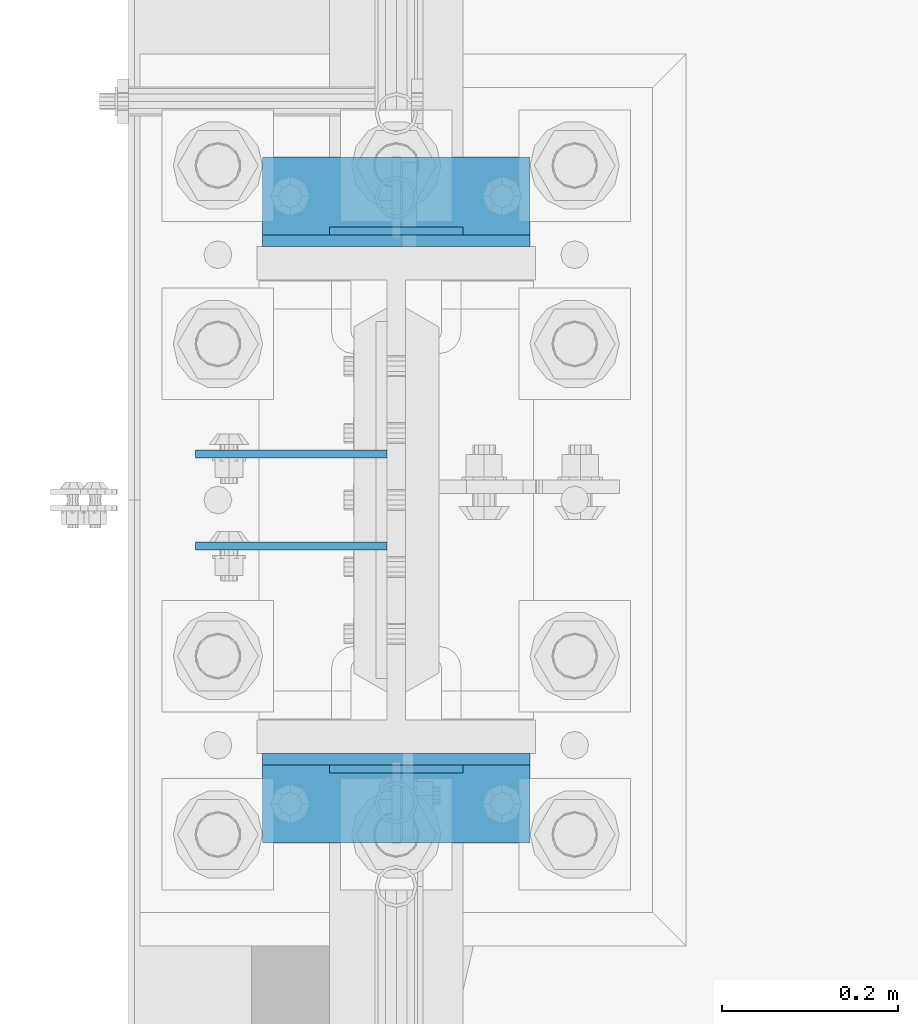
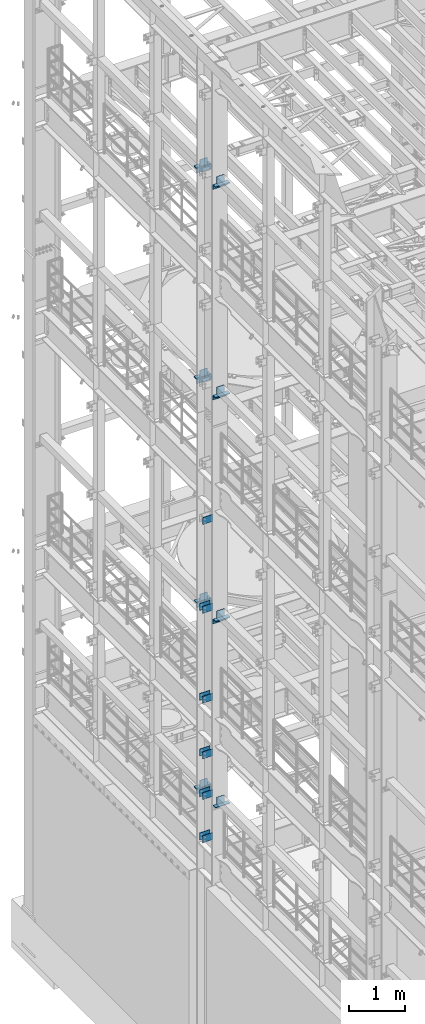
# One storey, part 1288 of 1876: 34 beams, 10 elements without a shape of their own.
"""IFC2X3 building model written with IfcOpenShell, lengths in millimetres."""

from ifc_helpers import new_model, si_unit, frame, origin_with_axes, place, context, subcontext, project, spatial, faceted_brep, material, type_object, element, aggregate, save


model = new_model("IFC2X3")

# Units and contexts
model_context = context("Model", 3, precision=1e-05, world=origin_with_axes())
body_context = subcontext(model_context, "Body", "Model", "MODEL_VIEW")
ifc_project = project(units=[si_unit("LENGTHUNIT", "METRE", prefix="MILLI"), si_unit("AREAUNIT", "SQUARE_METRE"), si_unit("VOLUMEUNIT", "CUBIC_METRE"), si_unit("MASSUNIT", "GRAM", prefix="KILO"), si_unit("TIMEUNIT", "SECOND"), si_unit("PLANEANGLEUNIT", "RADIAN"), si_unit("SOLIDANGLEUNIT", "STERADIAN"), si_unit("THERMODYNAMICTEMPERATUREUNIT", "DEGREE_CELSIUS"), si_unit("LUMINOUSINTENSITYUNIT", "LUMEN")], contexts=[model_context])

# Site, building, storey
site_placement = place(None, origin_with_axes())
site = spatial("IfcSite", under=ifc_project, at=site_placement, CompositionType="ELEMENT")
building_placement = place(site_placement, origin_with_axes())
building = spatial("IfcBuilding", under=site, at=building_placement, Name="Undefined", CompositionType="ELEMENT")
storey_placement = place(building_placement, origin_with_axes())
storey = spatial("IfcBuildingStorey", under=building, at=storey_placement, Name="Undefined", CompositionType="ELEMENT", Elevation=0.0)

# Assembly, beams
assembly_1_placement = place(storey_placement, origin_with_axes())
assembly_1 = element("IfcElementAssembly", 1, at=assembly_1_placement, inside=storey, Name="COLUMN", AssemblyPlace="NOTDEFINED", PredefinedType="RIGID_FRAME")
ifc_material = material(Name="STEEL/A36")
beam_type_1 = type_object("IfcBeamType", PredefinedType="NOTDEFINED")
beam_1_placement = place(assembly_1_placement, frame((-10.31875, 7567.61250076294, 12369.8), z_axis=(0.0, 0.0, -1.0), x_axis=(-1.0, 0.0, 0.0)))
beam_1 = element("IfcBeam", 2, at=beam_1_placement, type_object=beam_type_1, material=ifc_material, Name="PLATE", context=body_context, shape_type="Brep", body=[
    faceted_brep([(0.0, 4.76249999999982, -76.1999999999998), (3.63797880709171e-12, 4.76249999999982, 76.1999969482422), (218.28125, 4.76250000000005, 76.2000000000007), (218.28125, 4.76250000000005, -76.2000000000007), (3.63797880709171e-12, -4.76249999999982, 76.1999969482422), (218.28125, -4.76250000000005, 76.2000000000007), (0.0, -4.76249999999982, -76.1999999999998), (218.28125, -4.76250000000005, -76.2000000000007)], [[[0, 1, 2, 3]], [[1, 4, 5, 2]], [[4, 6, 7, 5]], [[6, 0, 3, 7]], [[5, 7, 3, 2]], [[6, 4, 1, 0]]]),
])
beam_2_placement = place(assembly_1_placement, frame((-10.31875, 7672.38750076294, 10420.35), z_axis=(0.0, 0.0, -1.0), x_axis=(-1.0, 0.0, 0.0)))
beam_2 = element("IfcBeam", 3, at=beam_2_placement, type_object=beam_type_1, material=ifc_material, Name="PLATE", context=body_context, shape_type="Brep", body=[
    faceted_brep([(0.0, 4.76249999999982, -76.1999999999998), (3.63797880709171e-12, 4.76249999999982, 76.1999969482422), (218.28125, 4.76250000000005, 76.2000000000007), (218.28125, 4.76250000000005, -76.2000000000007), (3.63797880709171e-12, -4.76249999999982, 76.1999969482422), (218.28125, -4.76250000000005, 76.2000000000007), (0.0, -4.76249999999982, -76.1999999999998), (218.28125, -4.76250000000005, -76.2000000000007)], [[[0, 1, 2, 3]], [[1, 4, 5, 2]], [[4, 6, 7, 5]], [[6, 0, 3, 7]], [[5, 7, 3, 2]], [[6, 4, 1, 0]]]),
])
beam_3_placement = place(assembly_1_placement, frame((-10.31875, 7567.61250076294, 10420.35), z_axis=(0.0, 0.0, -1.0), x_axis=(-1.0, 0.0, 0.0)))
beam_3 = element("IfcBeam", 4, at=beam_3_placement, type_object=beam_type_1, material=ifc_material, Name="PLATE", context=body_context, shape_type="Brep", body=[
    faceted_brep([(0.0, 4.76249999999982, -76.1999999999998), (3.63797880709171e-12, 4.76249999999982, 76.1999969482422), (218.28125, 4.76250000000005, 76.2000000000007), (218.28125, 4.76250000000005, -76.2000000000007), (3.63797880709171e-12, -4.76249999999982, 76.1999969482422), (218.28125, -4.76250000000005, 76.2000000000007), (0.0, -4.76249999999982, -76.1999999999998), (218.28125, -4.76250000000005, -76.2000000000007)], [[[0, 1, 2, 3]], [[1, 4, 5, 2]], [[4, 6, 7, 5]], [[6, 0, 3, 7]], [[5, 7, 3, 2]], [[6, 4, 1, 0]]]),
])
beam_4_placement = place(assembly_1_placement, frame((-10.31875, 7672.38750076294, 8445.5), z_axis=(0.0, 0.0, -1.0), x_axis=(-1.0, 0.0, 0.0)))
beam_4 = element("IfcBeam", 5, at=beam_4_placement, type_object=beam_type_1, material=ifc_material, Name="PLATE", context=body_context, shape_type="Brep", body=[
    faceted_brep([(0.0, 4.76249999999982, -76.1999999999998), (3.63797880709171e-12, 4.76249999999982, 76.1999969482422), (218.28125, 4.76250000000005, 76.2000000000007), (218.28125, 4.76250000000005, -76.2000000000007), (3.63797880709171e-12, -4.76249999999982, 76.1999969482422), (218.28125, -4.76250000000005, 76.2000000000007), (0.0, -4.76249999999982, -76.1999999999998), (218.28125, -4.76250000000005, -76.2000000000007)], [[[0, 1, 2, 3]], [[1, 4, 5, 2]], [[4, 6, 7, 5]], [[6, 0, 3, 7]], [[5, 7, 3, 2]], [[6, 4, 1, 0]]]),
])
beam_5_placement = place(assembly_1_placement, frame((-10.31875, 7567.61250076294, 8445.5), z_axis=(0.0, 0.0, -1.0), x_axis=(-1.0, 0.0, 0.0)))
beam_5 = element("IfcBeam", 6, at=beam_5_placement, type_object=beam_type_1, material=ifc_material, Name="PLATE", context=body_context, shape_type="Brep", body=[
    faceted_brep([(0.0, 4.76249999999982, -76.1999999999998), (3.63797880709171e-12, 4.76249999999982, 76.1999969482422), (218.28125, 4.76250000000005, 76.2000000000007), (218.28125, 4.76250000000005, -76.2000000000007), (3.63797880709171e-12, -4.76249999999982, 76.1999969482422), (218.28125, -4.76250000000005, 76.2000000000007), (0.0, -4.76249999999982, -76.1999999999998), (218.28125, -4.76250000000005, -76.2000000000007)], [[[0, 1, 2, 3]], [[1, 4, 5, 2]], [[4, 6, 7, 5]], [[6, 0, 3, 7]], [[5, 7, 3, 2]], [[6, 4, 1, 0]]]),
])
beam_6_placement = place(assembly_1_placement, frame((-10.31875, 7672.38750076294, 7226.3), z_axis=(0.0, 0.0, -1.0), x_axis=(-1.0, 0.0, 0.0)))
beam_6 = element("IfcBeam", 7, at=beam_6_placement, type_object=beam_type_1, material=ifc_material, Name="PLATE", context=body_context, shape_type="Brep", body=[
    faceted_brep([(0.0, 4.76249999999982, -76.1999999999998), (3.63797880709171e-12, 4.76249999999982, 76.1999969482422), (218.28125, 4.76250000000005, 76.2000000000007), (218.28125, 4.76250000000005, -76.2000000000007), (3.63797880709171e-12, -4.76249999999982, 76.1999969482422), (218.28125, -4.76250000000005, 76.2000000000007), (0.0, -4.76249999999982, -76.1999999999998), (218.28125, -4.76250000000005, -76.2000000000007)], [[[0, 1, 2, 3]], [[1, 4, 5, 2]], [[4, 6, 7, 5]], [[6, 0, 3, 7]], [[5, 7, 3, 2]], [[6, 4, 1, 0]]]),
])
beam_7_placement = place(assembly_1_placement, frame((-10.31875, 7567.61250076294, 7226.3), z_axis=(0.0, 0.0, -1.0), x_axis=(-1.0, 0.0, 0.0)))
beam_7 = element("IfcBeam", 8, at=beam_7_placement, type_object=beam_type_1, material=ifc_material, Name="PLATE", context=body_context, shape_type="Brep", body=[
    faceted_brep([(0.0, 4.76249999999982, -76.1999999999998), (3.63797880709171e-12, 4.76249999999982, 76.1999969482422), (218.28125, 4.76250000000005, 76.2000000000007), (218.28125, 4.76250000000005, -76.2000000000007), (3.63797880709171e-12, -4.76249999999982, 76.1999969482422), (218.28125, -4.76250000000005, 76.2000000000007), (0.0, -4.76249999999982, -76.1999999999998), (218.28125, -4.76250000000005, -76.2000000000007)], [[[0, 1, 2, 3]], [[1, 4, 5, 2]], [[4, 6, 7, 5]], [[6, 0, 3, 7]], [[5, 7, 3, 2]], [[6, 4, 1, 0]]]),
])
beam_8_placement = place(assembly_1_placement, frame((-10.31875, 7672.38750076294, 5384.8), z_axis=(0.0, 0.0, -1.0), x_axis=(-1.0, 0.0, 0.0)))
beam_8 = element("IfcBeam", 9, at=beam_8_placement, type_object=beam_type_1, material=ifc_material, Name="PLATE", context=body_context, shape_type="Brep", body=[
    faceted_brep([(0.0, 4.76249999999982, -76.1999999999998), (3.63797880709171e-12, 4.76249999999982, 76.1999969482422), (218.28125, 4.76250000000005, 76.2000000000007), (218.28125, 4.76250000000005, -76.2000000000007), (3.63797880709171e-12, -4.76249999999982, 76.1999969482422), (218.28125, -4.76250000000005, 76.2000000000007), (0.0, -4.76249999999982, -76.1999999999998), (218.28125, -4.76250000000005, -76.2000000000007)], [[[0, 1, 2, 3]], [[1, 4, 5, 2]], [[4, 6, 7, 5]], [[6, 0, 3, 7]], [[5, 7, 3, 2]], [[6, 4, 1, 0]]]),
])
beam_9_placement = place(assembly_1_placement, frame((-10.31875, 7567.61250076294, 5384.8), z_axis=(0.0, 0.0, -1.0), x_axis=(-1.0, 0.0, 0.0)))
beam_9 = element("IfcBeam", 10, at=beam_9_placement, type_object=beam_type_1, material=ifc_material, Name="PLATE", context=body_context, shape_type="Brep", body=[
    faceted_brep([(0.0, 4.76249999999982, -76.1999999999998), (3.63797880709171e-12, 4.76249999999982, 76.1999969482422), (218.28125, 4.76250000000005, 76.2000000000007), (218.28125, 4.76250000000005, -76.2000000000007), (3.63797880709171e-12, -4.76249999999982, 76.1999969482422), (218.28125, -4.76250000000005, 76.2000000000007), (0.0, -4.76249999999982, -76.1999999999998), (218.28125, -4.76250000000005, -76.2000000000007)], [[[0, 1, 2, 3]], [[1, 4, 5, 2]], [[4, 6, 7, 5]], [[6, 0, 3, 7]], [[5, 7, 3, 2]], [[6, 4, 1, 0]]]),
])
beam_10_placement = place(assembly_1_placement, frame((-10.31875, 7672.38750076294, 6330.95), z_axis=(0.0, 0.0, -1.0), x_axis=(-1.0, 0.0, 0.0)))
beam_10 = element("IfcBeam", 11, at=beam_10_placement, type_object=beam_type_1, material=ifc_material, Name="PLATE", context=body_context, shape_type="Brep", body=[
    faceted_brep([(0.0, 4.76249999999982, -76.1999999999998), (3.63797880709171e-12, 4.76249999999982, 76.1999969482422), (218.28125, 4.76250000000005, 76.2000000000007), (218.28125, 4.76250000000005, -76.2000000000007), (3.63797880709171e-12, -4.76249999999982, 76.1999969482422), (218.28125, -4.76250000000005, 76.2000000000007), (0.0, -4.76249999999982, -76.1999999999998), (218.28125, -4.76250000000005, -76.2000000000007)], [[[0, 1, 2, 3]], [[1, 4, 5, 2]], [[4, 6, 7, 5]], [[6, 0, 3, 7]], [[5, 7, 3, 2]], [[6, 4, 1, 0]]]),
])
beam_11_placement = place(assembly_1_placement, frame((-10.31875, 7567.61250076294, 6330.95), z_axis=(0.0, 0.0, -1.0), x_axis=(-1.0, 0.0, 0.0)))
beam_11 = element("IfcBeam", 12, at=beam_11_placement, type_object=beam_type_1, material=ifc_material, Name="PLATE", context=body_context, shape_type="Brep", body=[
    faceted_brep([(0.0, 4.76249999999982, -76.1999999999998), (3.63797880709171e-12, 4.76249999999982, 76.1999969482422), (218.28125, 4.76250000000005, 76.2000000000007), (218.28125, 4.76250000000005, -76.2000000000007), (3.63797880709171e-12, -4.76249999999982, 76.1999969482422), (218.28125, -4.76250000000005, 76.2000000000007), (0.0, -4.76249999999982, -76.1999999999998), (218.28125, -4.76250000000005, -76.2000000000007)], [[[0, 1, 2, 3]], [[1, 4, 5, 2]], [[4, 6, 7, 5]], [[6, 0, 3, 7]], [[5, 7, 3, 2]], [[6, 4, 1, 0]]]),
])

# Assembly, beam
assembly_2_placement = place(storey_placement, origin_with_axes())
assembly_2 = element("IfcElementAssembly", 13, at=assembly_2_placement, inside=storey, Name="BEAM", AssemblyPlace="NOTDEFINED", PredefinedType="RIGID_FRAME")
beam_12_placement = place(assembly_2_placement, frame((76.1999999999998, 7926.3875, 19958.05), z_axis=(0.0, 0.0, 1.0), x_axis=(-1.0, 0.0, 0.0)))
beam_12 = element("IfcBeam", 14, at=beam_12_placement, type_object=beam_type_1, material=ifc_material, Name="PLATE", context=body_context, shape_type="Brep", body=[
    faceted_brep([(0.0, 4.76249999999982, -76.1999999999998), (3.63797880709171e-12, 4.76249999999982, 76.1999969482422), (152.399993896484, 4.76250000000073, 76.1999969482422), (152.4, 4.76249999999982, -76.1999999999998), (3.63797880709171e-12, -4.76249999999982, 76.1999969482422), (152.399993896484, -4.76250000000073, 76.1999969482422), (0.0, -4.76249999999982, -76.1999999999998), (152.4, -4.76249999999982, -76.1999999999998)], [[[0, 1, 2, 3]], [[4, 5, 2, 1]], [[4, 6, 7, 5]], [[6, 0, 3, 7]], [[5, 7, 3, 2]], [[6, 4, 1, 0]]]),
])

assembly_3_placement = place(storey_placement, origin_with_axes())
assembly_3 = element("IfcElementAssembly", 15, at=assembly_3_placement, inside=storey, Name="BEAM", AssemblyPlace="NOTDEFINED", PredefinedType="RIGID_FRAME")
beam_13_placement = place(assembly_3_placement, frame((76.1999999999998, 7313.6125, 19958.05), z_axis=(0.0, 0.0, -1.0), x_axis=(-1.0, 0.0, 0.0)))
beam_13 = element("IfcBeam", 16, at=beam_13_placement, type_object=beam_type_1, material=ifc_material, Name="PLATE", context=body_context, shape_type="Brep", body=[
    faceted_brep([(0.0, 4.76249999999982, -76.1999999999998), (3.63797880709171e-12, 4.76249999999982, 76.1999969482422), (152.399993896484, 4.76250000000073, 76.1999969482422), (152.4, 4.76249999999982, -76.1999999999998), (3.63797880709171e-12, -4.76249999999982, 76.1999969482422), (152.399993896484, -4.76250000000073, 76.1999969482422), (0.0, -4.76249999999982, -76.1999999999998), (152.4, -4.76249999999982, -76.1999999999998)], [[[0, 1, 2, 3]], [[4, 5, 2, 1]], [[4, 6, 7, 5]], [[6, 0, 3, 7]], [[5, 7, 3, 2]], [[6, 4, 1, 0]]]),
])

assembly_4_placement = place(storey_placement, origin_with_axes())
assembly_4 = element("IfcElementAssembly", 17, at=assembly_4_placement, inside=storey, Name="BEAM", AssemblyPlace="NOTDEFINED", PredefinedType="RIGID_FRAME")
beam_14_placement = place(assembly_4_placement, frame((76.1999999999998, 7926.3875, 15335.25), z_axis=(0.0, 0.0, 1.0), x_axis=(-1.0, 0.0, 0.0)))
beam_14 = element("IfcBeam", 18, at=beam_14_placement, type_object=beam_type_1, material=ifc_material, Name="PLATE", context=body_context, shape_type="Brep", body=[
    faceted_brep([(0.0, 4.76249999999982, -76.1999999999998), (3.63797880709171e-12, 4.76249999999982, 76.1999969482422), (152.399993896484, 4.76250000000073, 76.1999969482422), (152.4, 4.76249999999982, -76.1999999999998), (3.63797880709171e-12, -4.76249999999982, 76.1999969482422), (152.399993896484, -4.76250000000073, 76.1999969482422), (0.0, -4.76249999999982, -76.1999999999998), (152.4, -4.76249999999982, -76.1999999999998)], [[[0, 1, 2, 3]], [[4, 5, 2, 1]], [[4, 6, 7, 5]], [[6, 0, 3, 7]], [[5, 7, 3, 2]], [[6, 4, 1, 0]]]),
])

assembly_5_placement = place(storey_placement, origin_with_axes())
assembly_5 = element("IfcElementAssembly", 19, at=assembly_5_placement, inside=storey, Name="BEAM", AssemblyPlace="NOTDEFINED", PredefinedType="RIGID_FRAME")
beam_15_placement = place(assembly_5_placement, frame((76.1999999999998, 7313.6125, 15335.25), z_axis=(0.0, 0.0, -1.0), x_axis=(-1.0, 0.0, 0.0)))
beam_15 = element("IfcBeam", 20, at=beam_15_placement, type_object=beam_type_1, material=ifc_material, Name="PLATE", context=body_context, shape_type="Brep", body=[
    faceted_brep([(0.0, 4.76249999999982, -76.1999999999998), (3.63797880709171e-12, 4.76249999999982, 76.1999969482422), (152.399993896484, 4.76250000000073, 76.1999969482422), (152.4, 4.76249999999982, -76.1999999999998), (3.63797880709171e-12, -4.76249999999982, 76.1999969482422), (152.399993896484, -4.76250000000073, 76.1999969482422), (0.0, -4.76249999999982, -76.1999999999998), (152.4, -4.76249999999982, -76.1999999999998)], [[[0, 1, 2, 3]], [[4, 5, 2, 1]], [[4, 6, 7, 5]], [[6, 0, 3, 7]], [[5, 7, 3, 2]], [[6, 4, 1, 0]]]),
])

assembly_6_placement = place(storey_placement, origin_with_axes())
assembly_6 = element("IfcElementAssembly", 21, at=assembly_6_placement, inside=storey, Name="BEAM", AssemblyPlace="NOTDEFINED", PredefinedType="RIGID_FRAME")
beam_16_placement = place(assembly_6_placement, frame((76.1999999999998, 7926.3875, 10420.35), z_axis=(0.0, 0.0, 1.0), x_axis=(-1.0, 0.0, 0.0)))
beam_16 = element("IfcBeam", 22, at=beam_16_placement, type_object=beam_type_1, material=ifc_material, Name="PLATE", context=body_context, shape_type="Brep", body=[
    faceted_brep([(0.0, 4.76249999999982, -76.1999999999998), (3.63797880709171e-12, 4.76249999999982, 76.1999969482422), (152.399993896484, 4.76250000000073, 76.1999969482422), (152.4, 4.76249999999982, -76.1999999999998), (3.63797880709171e-12, -4.76249999999982, 76.1999969482422), (152.399993896484, -4.76250000000073, 76.1999969482422), (0.0, -4.76249999999982, -76.1999999999998), (152.4, -4.76249999999982, -76.1999999999998)], [[[0, 1, 2, 3]], [[4, 5, 2, 1]], [[4, 6, 7, 5]], [[6, 0, 3, 7]], [[5, 7, 3, 2]], [[6, 4, 1, 0]]]),
])

assembly_7_placement = place(storey_placement, origin_with_axes())
assembly_7 = element("IfcElementAssembly", 23, at=assembly_7_placement, inside=storey, Name="BEAM", AssemblyPlace="NOTDEFINED", PredefinedType="RIGID_FRAME")
beam_17_placement = place(assembly_7_placement, frame((76.1999999999998, 7313.6125, 10420.35), z_axis=(0.0, 0.0, -1.0), x_axis=(-1.0, 0.0, 0.0)))
beam_17 = element("IfcBeam", 24, at=beam_17_placement, type_object=beam_type_1, material=ifc_material, Name="PLATE", context=body_context, shape_type="Brep", body=[
    faceted_brep([(0.0, 4.76249999999982, -76.1999999999998), (3.63797880709171e-12, 4.76249999999982, 76.1999969482422), (152.399993896484, 4.76250000000073, 76.1999969482422), (152.4, 4.76249999999982, -76.1999999999998), (3.63797880709171e-12, -4.76249999999982, 76.1999969482422), (152.399993896484, -4.76250000000073, 76.1999969482422), (0.0, -4.76249999999982, -76.1999999999998), (152.4, -4.76249999999982, -76.1999999999998)], [[[0, 1, 2, 3]], [[4, 5, 2, 1]], [[4, 6, 7, 5]], [[6, 0, 3, 7]], [[5, 7, 3, 2]], [[6, 4, 1, 0]]]),
])

assembly_8_placement = place(storey_placement, origin_with_axes())
assembly_8 = element("IfcElementAssembly", 25, at=assembly_8_placement, inside=storey, Name="BEAM", AssemblyPlace="NOTDEFINED", PredefinedType="RIGID_FRAME")
beam_18_placement = place(assembly_8_placement, frame((76.1999999999998, 7926.3875, 6330.95), z_axis=(0.0, 0.0, 1.0), x_axis=(-1.0, 0.0, 0.0)))
beam_18 = element("IfcBeam", 26, at=beam_18_placement, type_object=beam_type_1, material=ifc_material, Name="PLATE", context=body_context, shape_type="Brep", body=[
    faceted_brep([(0.0, 4.76249999999982, -76.1999999999998), (3.63797880709171e-12, 4.76249999999982, 76.1999969482422), (152.399993896484, 4.76250000000073, 76.1999969482422), (152.4, 4.76249999999982, -76.1999999999998), (3.63797880709171e-12, -4.76249999999982, 76.1999969482422), (152.399993896484, -4.76250000000073, 76.1999969482422), (0.0, -4.76249999999982, -76.1999999999998), (152.4, -4.76249999999982, -76.1999999999998)], [[[0, 1, 2, 3]], [[4, 5, 2, 1]], [[4, 6, 7, 5]], [[6, 0, 3, 7]], [[5, 7, 3, 2]], [[6, 4, 1, 0]]]),
])

assembly_9_placement = place(storey_placement, origin_with_axes())
assembly_9 = element("IfcElementAssembly", 27, at=assembly_9_placement, inside=storey, Name="BEAM", AssemblyPlace="NOTDEFINED", PredefinedType="RIGID_FRAME")
beam_19_placement = place(assembly_9_placement, frame((76.1999999999998, 7313.6125, 6330.95), z_axis=(0.0, 0.0, -1.0), x_axis=(-1.0, 0.0, 0.0)))
beam_19 = element("IfcBeam", 28, at=beam_19_placement, type_object=beam_type_1, material=ifc_material, Name="PLATE", context=body_context, shape_type="Brep", body=[
    faceted_brep([(0.0, 4.76249999999982, -76.1999999999998), (3.63797880709171e-12, 4.76249999999982, 76.1999969482422), (152.399993896484, 4.76250000000073, 76.1999969482422), (152.4, 4.76249999999982, -76.1999999999998), (3.63797880709171e-12, -4.76249999999982, 76.1999969482422), (152.399993896484, -4.76250000000073, 76.1999969482422), (0.0, -4.76249999999982, -76.1999999999998), (152.4, -4.76249999999982, -76.1999999999998)], [[[0, 1, 2, 3]], [[4, 5, 2, 1]], [[4, 6, 7, 5]], [[6, 0, 3, 7]], [[5, 7, 3, 2]], [[6, 4, 1, 0]]]),
])

# Beam
beam_type_2 = type_object("IfcBeamType", PredefinedType="NOTDEFINED")
beam_20_placement = place(assembly_2_placement, frame((-152.400000000001, 7966.075, 19877.0875), z_axis=(0.0, 1.0, 0.0), x_axis=(1.0, 0.0, 0.0)))
beam_20 = element("IfcBeam", 29, at=beam_20_placement, type_object=beam_type_2, material=ifc_material, Name="PLATE", context=body_context, shape_type="Brep", body=[
    faceted_brep([(0.0, 4.76250000000073, -44.4499999999998), (0.0, 4.76250000000073, 44.4499999999998), (304.799999999999, 4.76250000000073, 44.4499999999998), (304.799999999999, 4.76250000000073, -44.4499999999998), (0.0, -4.76250000000073, 44.4499999999998), (304.799999999999, -4.76250000000073, 44.4499999999998), (0.0, -4.76250000000073, -44.4499999999998), (304.799999999999, -4.76250000000073, -44.4499999999998)], [[[0, 1, 2, 3]], [[1, 4, 5, 2]], [[4, 6, 7, 5]], [[6, 0, 3, 7]], [[5, 7, 3, 2]], [[6, 4, 1, 0]]]),
])

aggregate(assembly_2, [beam_12, beam_20])

beam_21_placement = place(assembly_3_placement, frame((-152.400000000001, 7273.925, 19877.0875), z_axis=(0.0, -1.0, 0.0), x_axis=(1.0, 0.0, 0.0)))
beam_21 = element("IfcBeam", 30, at=beam_21_placement, type_object=beam_type_2, material=ifc_material, Name="PLATE", context=body_context, shape_type="Brep", body=[
    faceted_brep([(0.0, 4.76250000000073, -44.4499999999998), (0.0, 4.76250000000073, 44.4499999999998), (304.799999999999, 4.76250000000073, 44.4499999999998), (304.799999999999, 4.76250000000073, -44.4499999999998), (0.0, -4.76250000000073, 44.4499999999998), (304.799999999999, -4.76250000000073, 44.4499999999998), (0.0, -4.76250000000073, -44.4499999999998), (304.799999999999, -4.76250000000073, -44.4499999999998)], [[[0, 1, 2, 3]], [[1, 4, 5, 2]], [[4, 6, 7, 5]], [[6, 0, 3, 7]], [[5, 7, 3, 2]], [[6, 4, 1, 0]]]),
])

aggregate(assembly_3, [beam_13, beam_21])

beam_22_placement = place(assembly_4_placement, frame((-152.400000000001, 7966.075, 15254.2875), z_axis=(0.0, 1.0, 0.0), x_axis=(1.0, 0.0, 0.0)))
beam_22 = element("IfcBeam", 31, at=beam_22_placement, type_object=beam_type_2, material=ifc_material, Name="PLATE", context=body_context, shape_type="Brep", body=[
    faceted_brep([(0.0, 4.76250000000073, -44.4499999999998), (0.0, 4.76250000000073, 44.4499999999998), (304.799999999999, 4.76250000000073, 44.4499999999998), (304.799999999999, 4.76250000000073, -44.4499999999998), (0.0, -4.76250000000073, 44.4499999999998), (304.799999999999, -4.76250000000073, 44.4499999999998), (0.0, -4.76250000000073, -44.4499999999998), (304.799999999999, -4.76250000000073, -44.4499999999998)], [[[0, 1, 2, 3]], [[1, 4, 5, 2]], [[4, 6, 7, 5]], [[6, 0, 3, 7]], [[5, 7, 3, 2]], [[6, 4, 1, 0]]]),
])

aggregate(assembly_4, [beam_14, beam_22])

beam_23_placement = place(assembly_5_placement, frame((-152.400000000001, 7273.925, 15254.2875), z_axis=(0.0, -1.0, 0.0), x_axis=(1.0, 0.0, 0.0)))
beam_23 = element("IfcBeam", 32, at=beam_23_placement, type_object=beam_type_2, material=ifc_material, Name="PLATE", context=body_context, shape_type="Brep", body=[
    faceted_brep([(0.0, 4.76250000000073, -44.4499999999998), (0.0, 4.76250000000073, 44.4499999999998), (304.799999999999, 4.76250000000073, 44.4499999999998), (304.799999999999, 4.76250000000073, -44.4499999999998), (0.0, -4.76250000000073, 44.4499999999998), (304.799999999999, -4.76250000000073, 44.4499999999998), (0.0, -4.76250000000073, -44.4499999999998), (304.799999999999, -4.76250000000073, -44.4499999999998)], [[[0, 1, 2, 3]], [[1, 4, 5, 2]], [[4, 6, 7, 5]], [[6, 0, 3, 7]], [[5, 7, 3, 2]], [[6, 4, 1, 0]]]),
])

aggregate(assembly_5, [beam_15, beam_23])

beam_24_placement = place(assembly_6_placement, frame((-152.400000000001, 7966.075, 10339.3875), z_axis=(0.0, 1.0, 0.0), x_axis=(1.0, 0.0, 0.0)))
beam_24 = element("IfcBeam", 33, at=beam_24_placement, type_object=beam_type_2, material=ifc_material, Name="PLATE", context=body_context, shape_type="Brep", body=[
    faceted_brep([(0.0, 4.76250000000073, -44.4499999999998), (0.0, 4.76250000000073, 44.4499999999998), (304.799999999999, 4.76250000000073, 44.4499999999998), (304.799999999999, 4.76250000000073, -44.4499999999998), (0.0, -4.76250000000073, 44.4499999999998), (304.799999999999, -4.76250000000073, 44.4499999999998), (0.0, -4.76250000000073, -44.4499999999998), (304.799999999999, -4.76250000000073, -44.4499999999998)], [[[0, 1, 2, 3]], [[1, 4, 5, 2]], [[4, 6, 7, 5]], [[6, 0, 3, 7]], [[5, 7, 3, 2]], [[6, 4, 1, 0]]]),
])

aggregate(assembly_6, [beam_16, beam_24])

beam_25_placement = place(assembly_7_placement, frame((-152.400000000001, 7273.925, 10339.3875), z_axis=(0.0, -1.0, 0.0), x_axis=(1.0, 0.0, 0.0)))
beam_25 = element("IfcBeam", 34, at=beam_25_placement, type_object=beam_type_2, material=ifc_material, Name="PLATE", context=body_context, shape_type="Brep", body=[
    faceted_brep([(0.0, 4.76250000000073, -44.4499999999998), (0.0, 4.76250000000073, 44.4499999999998), (304.799999999999, 4.76250000000073, 44.4499999999998), (304.799999999999, 4.76250000000073, -44.4499999999998), (0.0, -4.76250000000073, 44.4499999999998), (304.799999999999, -4.76250000000073, 44.4499999999998), (0.0, -4.76250000000073, -44.4499999999998), (304.799999999999, -4.76250000000073, -44.4499999999998)], [[[0, 1, 2, 3]], [[1, 4, 5, 2]], [[4, 6, 7, 5]], [[6, 0, 3, 7]], [[5, 7, 3, 2]], [[6, 4, 1, 0]]]),
])

aggregate(assembly_7, [beam_17, beam_25])

beam_26_placement = place(assembly_8_placement, frame((-152.400000000001, 7966.075, 6249.9875), z_axis=(0.0, 1.0, 0.0), x_axis=(1.0, 0.0, 0.0)))
beam_26 = element("IfcBeam", 35, at=beam_26_placement, type_object=beam_type_2, material=ifc_material, Name="PLATE", context=body_context, shape_type="Brep", body=[
    faceted_brep([(0.0, 4.76250000000073, -44.4499999999998), (0.0, 4.76250000000073, 44.4499999999998), (304.799999999999, 4.76250000000073, 44.4499999999998), (304.799999999999, 4.76250000000073, -44.4499999999998), (0.0, -4.76250000000073, 44.4499999999998), (304.799999999999, -4.76250000000073, 44.4499999999998), (0.0, -4.76250000000073, -44.4499999999998), (304.799999999999, -4.76250000000073, -44.4499999999998)], [[[0, 1, 2, 3]], [[1, 4, 5, 2]], [[4, 6, 7, 5]], [[6, 0, 3, 7]], [[5, 7, 3, 2]], [[6, 4, 1, 0]]]),
])

aggregate(assembly_8, [beam_18, beam_26])

beam_27_placement = place(assembly_9_placement, frame((-152.400000000001, 7273.925, 6249.9875), z_axis=(0.0, -1.0, 0.0), x_axis=(1.0, 0.0, 0.0)))
beam_27 = element("IfcBeam", 36, at=beam_27_placement, type_object=beam_type_2, material=ifc_material, Name="PLATE", context=body_context, shape_type="Brep", body=[
    faceted_brep([(0.0, 4.76250000000073, -44.4499999999998), (0.0, 4.76250000000073, 44.4499999999998), (304.799999999999, 4.76250000000073, 44.4499999999998), (304.799999999999, 4.76250000000073, -44.4499999999998), (0.0, -4.76250000000073, 44.4499999999998), (304.799999999999, -4.76250000000073, 44.4499999999998), (0.0, -4.76250000000073, -44.4499999999998), (304.799999999999, -4.76250000000073, -44.4499999999998)], [[[0, 1, 2, 3]], [[1, 4, 5, 2]], [[4, 6, 7, 5]], [[6, 0, 3, 7]], [[5, 7, 3, 2]], [[6, 4, 1, 0]]]),
])

aggregate(assembly_9, [beam_19, beam_27])

# Assembly, beams
assembly_10_placement = place(storey_placement, origin_with_axes())
assembly_10 = element("IfcElementAssembly", 37, at=assembly_10_placement, inside=storey, Name="COLUMN", AssemblyPlace="NOTDEFINED", PredefinedType="RIGID_FRAME")
beam_type_3 = type_object("IfcBeamType", Name="L4X4X3/8", PredefinedType="NOTDEFINED")
beam_28_placement = place(assembly_10_placement, frame((152.4, 7959.725, 19821.525), z_axis=(0.0, 1.0, 0.0), x_axis=(-1.0, 0.0, 0.0)))
beam_28 = element("IfcBeam", 38, at=beam_28_placement, type_object=beam_type_3, material=ifc_material, Name="ANGLE", ObjectType="L4X4X3/8", context=body_context, shape_type="Brep", body=[
    faceted_brep([(0.0, 50.7999999999993, -50.8000000000002), (0.0, 50.7999999999993, 50.8000000000002), (304.799999999999, 50.7999999999993, 50.8000000000002), (304.799999999999, 50.7999999999993, -50.8000000000002), (0.0, 41.2750000000015, 50.8000000000002), (304.799999999999, 41.2750000000015, 50.8000000000002), (0.0, 41.2750000000015, -41.2749999999996), (304.799999999999, 41.2750000000015, -41.2749999999996), (0.0, -50.7999999999993, -41.2749999999996), (304.799999999999, -50.7999999999993, -41.2749999999996), (0.0, -50.7999999999993, -50.8000000000002), (304.799999999999, -50.7999999999993, -50.8000000000002)], [[[0, 1, 2, 3]], [[1, 4, 5, 2]], [[4, 6, 7, 5]], [[6, 8, 9, 7]], [[8, 10, 11, 9]], [[10, 0, 3, 11]], [[5, 7, 9, 11, 3, 2]], [[10, 8, 6, 4, 1, 0]]]),
])
beam_29_placement = place(assembly_10_placement, frame((-152.400000000001, 7280.275, 19821.525), z_axis=(0.0, -1.0, 0.0), x_axis=(1.0, 0.0, 0.0)))
beam_29 = element("IfcBeam", 39, at=beam_29_placement, type_object=beam_type_3, material=ifc_material, Name="ANGLE", ObjectType="L4X4X3/8", context=body_context, shape_type="Brep", body=[
    faceted_brep([(0.0, 50.7999999999993, -50.8000000000002), (0.0, 50.7999999999993, 50.8000000000002), (304.799999999999, 50.7999999999993, 50.8000000000002), (304.799999999999, 50.7999999999993, -50.8000000000002), (0.0, 41.2750000000015, 50.8000000000002), (304.799999999999, 41.2750000000015, 50.8000000000002), (0.0, 41.2750000000015, -41.2749999999996), (304.799999999999, 41.2750000000015, -41.2749999999996), (0.0, -50.7999999999993, -41.2749999999996), (304.799999999999, -50.7999999999993, -41.2749999999996), (0.0, -50.7999999999993, -50.8000000000002), (304.799999999999, -50.7999999999993, -50.8000000000002)], [[[0, 1, 2, 3]], [[1, 4, 5, 2]], [[4, 6, 7, 5]], [[6, 8, 9, 7]], [[8, 10, 11, 9]], [[10, 0, 3, 11]], [[5, 7, 9, 11, 3, 2]], [[10, 8, 6, 4, 1, 0]]]),
])
beam_30_placement = place(assembly_10_placement, frame((152.4, 7959.725, 15198.725), z_axis=(0.0, 1.0, 0.0), x_axis=(-1.0, 0.0, 0.0)))
beam_30 = element("IfcBeam", 40, at=beam_30_placement, type_object=beam_type_3, material=ifc_material, Name="ANGLE", ObjectType="L4X4X3/8", context=body_context, shape_type="Brep", body=[
    faceted_brep([(0.0, 50.7999999999993, -50.8000000000002), (0.0, 50.7999999999993, 50.8000000000002), (304.799999999999, 50.7999999999993, 50.8000000000002), (304.799999999999, 50.7999999999993, -50.8000000000002), (0.0, 41.2750000000015, 50.8000000000002), (304.799999999999, 41.2750000000015, 50.8000000000002), (0.0, 41.2750000000015, -41.2749999999996), (304.799999999999, 41.2750000000015, -41.2749999999996), (0.0, -50.7999999999993, -41.2749999999996), (304.799999999999, -50.7999999999993, -41.2749999999996), (0.0, -50.7999999999993, -50.8000000000002), (304.799999999999, -50.7999999999993, -50.8000000000002)], [[[0, 1, 2, 3]], [[1, 4, 5, 2]], [[4, 6, 7, 5]], [[6, 8, 9, 7]], [[8, 10, 11, 9]], [[10, 0, 3, 11]], [[5, 7, 9, 11, 3, 2]], [[10, 8, 6, 4, 1, 0]]]),
])
beam_31_placement = place(assembly_10_placement, frame((-152.400000000001, 7280.275, 15198.725), z_axis=(0.0, -1.0, 0.0), x_axis=(1.0, 0.0, 0.0)))
beam_31 = element("IfcBeam", 41, at=beam_31_placement, type_object=beam_type_3, material=ifc_material, Name="ANGLE", ObjectType="L4X4X3/8", context=body_context, shape_type="Brep", body=[
    faceted_brep([(0.0, 50.7999999999993, -50.8000000000002), (0.0, 50.7999999999993, 50.8000000000002), (304.799999999999, 50.7999999999993, 50.8000000000002), (304.799999999999, 50.7999999999993, -50.8000000000002), (0.0, 41.2750000000015, 50.8000000000002), (304.799999999999, 41.2750000000015, 50.8000000000002), (0.0, 41.2750000000015, -41.2749999999996), (304.799999999999, 41.2750000000015, -41.2749999999996), (0.0, -50.7999999999993, -41.2749999999996), (304.799999999999, -50.7999999999993, -41.2749999999996), (0.0, -50.7999999999993, -50.8000000000002), (304.799999999999, -50.7999999999993, -50.8000000000002)], [[[0, 1, 2, 3]], [[1, 4, 5, 2]], [[4, 6, 7, 5]], [[6, 8, 9, 7]], [[8, 10, 11, 9]], [[10, 0, 3, 11]], [[5, 7, 9, 11, 3, 2]], [[10, 8, 6, 4, 1, 0]]]),
])
aggregate(assembly_10, [beam_28, beam_29, beam_30, beam_31])

# Beam
beam_32_placement = place(assembly_1_placement, frame((152.4, 7959.725, 10283.825), z_axis=(0.0, 1.0, 0.0), x_axis=(-1.0, 0.0, 0.0)))
beam_32 = element("IfcBeam", 42, at=beam_32_placement, type_object=beam_type_3, material=ifc_material, Name="ANGLE", ObjectType="L4X4X3/8", context=body_context, shape_type="Brep", body=[
    faceted_brep([(0.0, 50.7999999999993, -50.8000000000002), (0.0, 50.7999999999993, 50.8000000000002), (304.799999999999, 50.7999999999993, 50.8000000000002), (304.799999999999, 50.7999999999993, -50.8000000000002), (0.0, 41.2750000000015, 50.8000000000002), (304.799999999999, 41.2750000000015, 50.8000000000002), (0.0, 41.2750000000015, -41.2749999999996), (304.799999999999, 41.2750000000015, -41.2749999999996), (0.0, -50.7999999999993, -41.2749999999996), (304.799999999999, -50.7999999999993, -41.2749999999996), (0.0, -50.7999999999993, -50.8000000000002), (304.799999999999, -50.7999999999993, -50.8000000000002)], [[[0, 1, 2, 3]], [[1, 4, 5, 2]], [[4, 6, 7, 5]], [[6, 8, 9, 7]], [[8, 10, 11, 9]], [[10, 0, 3, 11]], [[5, 7, 9, 11, 3, 2]], [[10, 8, 6, 4, 1, 0]]]),
])

beam_33_placement = place(assembly_1_placement, frame((-152.400000000001, 7280.275, 10283.825), z_axis=(0.0, -1.0, 0.0), x_axis=(1.0, 0.0, 0.0)))
beam_33 = element("IfcBeam", 43, at=beam_33_placement, type_object=beam_type_3, material=ifc_material, Name="ANGLE", ObjectType="L4X4X3/8", context=body_context, shape_type="Brep", body=[
    faceted_brep([(0.0, 50.7999999999993, -50.8000000000002), (0.0, 50.7999999999993, 50.8000000000002), (304.799999999999, 50.7999999999993, 50.8000000000002), (304.799999999999, 50.7999999999993, -50.8000000000002), (0.0, 41.2750000000015, 50.8000000000002), (304.799999999999, 41.2750000000015, 50.8000000000002), (0.0, 41.2750000000015, -41.2749999999996), (304.799999999999, 41.2750000000015, -41.2749999999996), (0.0, -50.7999999999993, -41.2749999999996), (304.799999999999, -50.7999999999993, -41.2749999999996), (0.0, -50.7999999999993, -50.8000000000002), (304.799999999999, -50.7999999999993, -50.8000000000002)], [[[0, 1, 2, 3]], [[1, 4, 5, 2]], [[4, 6, 7, 5]], [[6, 8, 9, 7]], [[8, 10, 11, 9]], [[10, 0, 3, 11]], [[5, 7, 9, 11, 3, 2]], [[10, 8, 6, 4, 1, 0]]]),
])

beam_34_placement = place(assembly_1_placement, frame((152.4, 7959.725, 6194.425), z_axis=(0.0, 1.0, 0.0), x_axis=(-1.0, 0.0, 0.0)))
beam_34 = element("IfcBeam", 44, at=beam_34_placement, type_object=beam_type_3, material=ifc_material, Name="ANGLE", ObjectType="L4X4X3/8", context=body_context, shape_type="Brep", body=[
    faceted_brep([(0.0, 50.7999999999993, -50.8000000000002), (0.0, 50.7999999999993, 50.8000000000002), (304.799999999999, 50.7999999999993, 50.8000000000002), (304.799999999999, 50.7999999999993, -50.8000000000002), (0.0, 41.2750000000015, 50.8000000000002), (304.799999999999, 41.2750000000015, 50.8000000000002), (0.0, 41.2750000000015, -41.2749999999996), (304.799999999999, 41.2750000000015, -41.2749999999996), (0.0, -50.7999999999993, -41.2749999999996), (304.799999999999, -50.7999999999993, -41.2749999999996), (0.0, -50.7999999999993, -50.8000000000002), (304.799999999999, -50.7999999999993, -50.8000000000002)], [[[0, 1, 2, 3]], [[1, 4, 5, 2]], [[4, 6, 7, 5]], [[6, 8, 9, 7]], [[8, 10, 11, 9]], [[10, 0, 3, 11]], [[5, 7, 9, 11, 3, 2]], [[10, 8, 6, 4, 1, 0]]]),
])

aggregate(assembly_1, [beam_1, beam_2, beam_3, beam_4, beam_5, beam_6, beam_7, beam_8, beam_9, beam_10, beam_11, beam_32, beam_33, beam_34])

save(model, "model.ifc")
